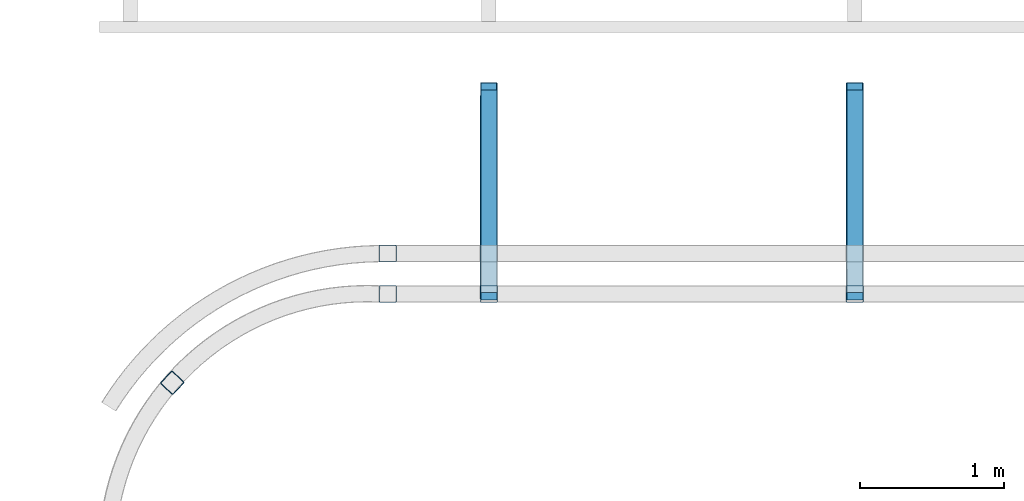
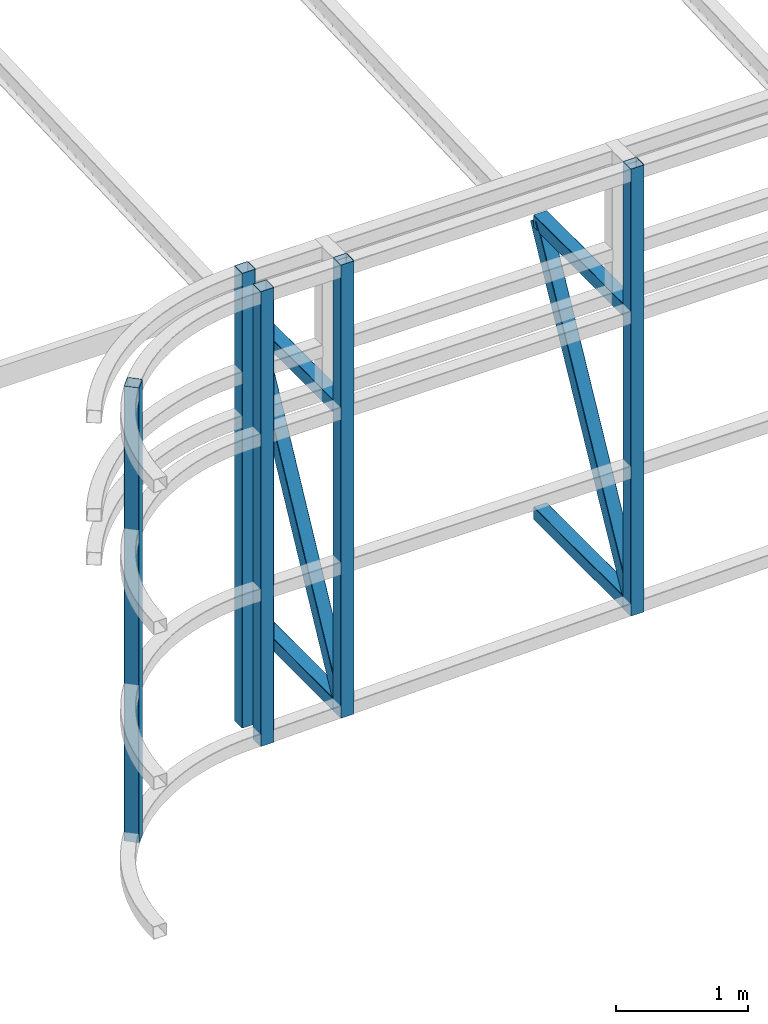
# One storey, part 105 of 215: 9 beams, 2 members, 11 elements without a shape of their own.
"""IFC2X3 building model written with IfcOpenShell, lengths in millimetres."""

from ifc_helpers import new_model, si_unit, frame, origin_with_axes, origin_2d_with_axis, place, context, subcontext, project, spatial, hollow_rectangle, extrude, material, type_object, element, aggregate, save


model = new_model("IFC2X3")

# Units and contexts
model_context = context("Model", 3, precision=1e-05, world=origin_with_axes())
body_context = subcontext(model_context, "Body", "Model", "MODEL_VIEW")
ifc_project = project(units=[si_unit("LENGTHUNIT", "METRE", prefix="MILLI"), si_unit("AREAUNIT", "SQUARE_METRE"), si_unit("VOLUMEUNIT", "CUBIC_METRE"), si_unit("MASSUNIT", "GRAM", prefix="KILO"), si_unit("TIMEUNIT", "SECOND"), si_unit("PLANEANGLEUNIT", "RADIAN"), si_unit("SOLIDANGLEUNIT", "STERADIAN"), si_unit("THERMODYNAMICTEMPERATUREUNIT", "DEGREE_CELSIUS"), si_unit("LUMINOUSINTENSITYUNIT", "LUMEN")], contexts=[model_context])

# Site, building, storey
site_placement = place(None, origin_with_axes())
site = spatial("IfcSite", under=ifc_project, at=site_placement, CompositionType="ELEMENT")
building_placement = place(site_placement, origin_with_axes())
building = spatial("IfcBuilding", under=site, at=building_placement, Name="Undefined", CompositionType="ELEMENT")
storey_placement = place(building_placement, origin_with_axes())
storey = spatial("IfcBuildingStorey", under=building, at=storey_placement, Name="Undefined", CompositionType="ELEMENT", Elevation=0.0)

# Assembly, beam
assembly_1_placement = place(storey_placement, origin_with_axes())
assembly_1 = element("IfcElementAssembly", 1, at=assembly_1_placement, inside=storey, Name="Steel Assembly", AssemblyPlace="NOTDEFINED", PredefinedType="RIGID_FRAME")
ifc_material = material(Name="STEEL/S275JR")
beam_type = type_object("IfcBeamType", PredefinedType="NOTDEFINED")
beam_1_placement = place(assembly_1_placement, frame((105963.049496376, 33419.9401986617, 4339.19100733164), z_axis=(-1.22999999439251e-06, -0.999999999999244, 0.0), x_axis=(0.0, 0.0, -1.0)))
beam_1 = element("IfcBeam", 2, at=beam_1_placement, type_object=beam_type, material=ifc_material, Name="LISSE", context=body_context, shape_type="SweptSolid", body=[
    extrude(hollow_rectangle(XDim=120.0, YDim=120.0, WallThickness=4.0, InnerFilletRadius=4.0, OuterFilletRadius=8.0, at=origin_2d_with_axis()), frame((4212.27305213816, 0.0, 0.0), z_axis=(-1.0, 0.0, 0.0), x_axis=(-6.93889390390723e-18, -1.0, -3.46944695195361e-18)), (0.0, 0.0, 1.0), 4212.3),
])
aggregate(assembly_1, [beam_1])

assembly_2_placement = place(storey_placement, origin_with_axes())
assembly_2 = element("IfcElementAssembly", 3, at=assembly_2_placement, inside=storey, Name="Steel Assembly", AssemblyPlace="NOTDEFINED", PredefinedType="RIGID_FRAME")
beam_2_placement = place(assembly_2_placement, frame((106665.007214263, 34554.8740277617, 201.30219434025), z_axis=(0.0, 0.0, 1.0), x_axis=(-6.93889390390723e-18, -1.0, -3.46944695195361e-18)))
beam_2 = element("IfcBeam", 4, at=beam_2_placement, type_object=beam_type, material=ifc_material, Name="LISSE", context=body_context, shape_type="SweptSolid", body=[
    extrude(hollow_rectangle(XDim=120.0, YDim=120.0, WallThickness=4.0, InnerFilletRadius=4.0, OuterFilletRadius=8.0, at=origin_2d_with_axis()), frame((1404.9181154153, 1.48751491493898e-19, -2.84217094304217e-14), z_axis=(-1.0, 0.0, 0.0), x_axis=(-6.93889390390723e-18, -1.0, -3.46944695195361e-18)), (0.0, 0.0, 1.0), 1404.9),
])
aggregate(assembly_2, [beam_2])

assembly_3_placement = place(storey_placement, origin_with_axes())
assembly_3 = element("IfcElementAssembly", 5, at=assembly_3_placement, inside=storey, Name="Steel Assembly", AssemblyPlace="NOTDEFINED", PredefinedType="RIGID_FRAME")
beam_3_placement = place(assembly_3_placement, frame((109205.009155207, 34554.8788879734, 258.197990203861), z_axis=(0.0, 0.0, 1.0), x_axis=(-6.93889390390723e-18, -1.0, -3.46944695195361e-18)))
beam_3 = element("IfcBeam", 6, at=beam_3_placement, type_object=beam_type, material=ifc_material, Name="LISSE", context=body_context, shape_type="SweptSolid", body=[
    extrude(hollow_rectangle(XDim=120.0, YDim=120.0, WallThickness=4.0, InnerFilletRadius=4.0, OuterFilletRadius=8.0, at=origin_2d_with_axis()), frame((1404.9181154153, 1.48751491493898e-19, -2.84217094304217e-14), z_axis=(-1.0, 0.0, 0.0), x_axis=(-6.93889390390723e-18, -1.0, -3.46944695195361e-18)), (0.0, 0.0, 1.0), 1404.9),
])
aggregate(assembly_3, [beam_3])

assembly_4_placement = place(storey_placement, origin_with_axes())
assembly_4 = element("IfcElementAssembly", 7, at=assembly_4_placement, inside=storey, Name="Steel Assembly", AssemblyPlace="NOTDEFINED", PredefinedType="RIGID_FRAME")
beam_4_placement = place(assembly_4_placement, frame((106665.008622264, 34554.8706212946, 2963.99602185051), z_axis=(0.0, 0.0, -1.0), x_axis=(-4.41999996209638e-07, -0.999999999999642, 7.22000000069896e-07)))
beam_4 = element("IfcBeam", 8, at=beam_4_placement, type_object=beam_type, material=ifc_material, Name="LISSE", context=body_context, shape_type="SweptSolid", body=[
    extrude(hollow_rectangle(XDim=120.0, YDim=120.0, WallThickness=4.0, InnerFilletRadius=4.0, OuterFilletRadius=8.0, at=origin_2d_with_axis()), frame((1404.89231313232, 5.39143026605448e-20, -1.48748759570922e-19), z_axis=(-1.0, 0.0, 0.0), x_axis=(-6.93889390390723e-18, -1.0, -3.46944695195361e-18)), (0.0, 0.0, 1.0), 1404.9),
])
aggregate(assembly_4, [beam_4])

assembly_5_placement = place(storey_placement, origin_with_axes())
assembly_5 = element("IfcElementAssembly", 9, at=assembly_5_placement, inside=storey, Name="Steel Assembly", AssemblyPlace="NOTDEFINED", PredefinedType="RIGID_FRAME")
beam_5_placement = place(assembly_5_placement, frame((109205.010563199, 34554.8754815795, 2963.99602185051), z_axis=(0.0, 0.0, -1.0), x_axis=(-4.41999996209638e-07, -0.999999999999642, 7.22000000069896e-07)))
beam_5 = element("IfcBeam", 10, at=beam_5_placement, type_object=beam_type, material=ifc_material, Name="LISSE", context=body_context, shape_type="SweptSolid", body=[
    extrude(hollow_rectangle(XDim=120.0, YDim=120.0, WallThickness=4.0, InnerFilletRadius=4.0, OuterFilletRadius=8.0, at=origin_2d_with_axis()), frame((1404.89231313232, 5.39143026605448e-20, -1.48748759570922e-19), z_axis=(-1.0, 0.0, 0.0), x_axis=(-6.93889390390723e-18, -1.0, -3.46944695195361e-18)), (0.0, 0.0, 1.0), 1404.9),
])
aggregate(assembly_5, [beam_5])

assembly_6_placement = place(storey_placement, origin_with_axes())
assembly_6 = element("IfcElementAssembly", 11, at=assembly_6_placement, inside=storey, Name="Steel Assembly", AssemblyPlace="NOTDEFINED", PredefinedType="RIGID_FRAME")
beam_6_placement = place(assembly_6_placement, frame((104467.161682127, 32523.1638216692, 4339.19096643382), z_axis=(0.730130673706851, -0.68330754372565, 0.0), x_axis=(0.0, 0.0, -1.0)))
beam_6 = element("IfcBeam", 12, at=beam_6_placement, type_object=beam_type, material=ifc_material, Name="LISSE", context=body_context, shape_type="SweptSolid", body=[
    extrude(hollow_rectangle(XDim=120.0, YDim=120.0, WallThickness=4.0, InnerFilletRadius=4.0, OuterFilletRadius=8.0, at=origin_2d_with_axis()), frame((4212.27305213816, 0.0, 0.0), z_axis=(-1.0, 0.0, 0.0), x_axis=(-6.93889390390723e-18, -1.0, -3.46944695195361e-18)), (0.0, 0.0, 1.0), 4212.3),
])
aggregate(assembly_6, [beam_6])

assembly_7_placement = place(storey_placement, origin_with_axes())
assembly_7 = element("IfcElementAssembly", 13, at=assembly_7_placement, inside=storey, Name="Steel Assembly", AssemblyPlace="NOTDEFINED", PredefinedType="RIGID_FRAME")
beam_7_placement = place(assembly_7_placement, frame((105963.050128326, 33139.9104810815, 4339.19097141913), z_axis=(-1.22999999439251e-06, -0.999999999999244, 0.0), x_axis=(0.0, 0.0, -1.0)))
beam_7 = element("IfcBeam", 14, at=beam_7_placement, type_object=beam_type, material=ifc_material, Name="LISSE", context=body_context, shape_type="SweptSolid", body=[
    extrude(hollow_rectangle(XDim=120.0, YDim=120.0, WallThickness=4.0, InnerFilletRadius=4.0, OuterFilletRadius=8.0, at=origin_2d_with_axis()), frame((4212.27305213816, 0.0, 0.0), z_axis=(-1.0, 0.0, 0.0), x_axis=(-6.93889390390723e-18, -1.0, -3.46944695195361e-18)), (0.0, 0.0, 1.0), 4212.3),
])
aggregate(assembly_7, [beam_7])

assembly_8_placement = place(storey_placement, origin_with_axes())
assembly_8 = element("IfcElementAssembly", 15, at=assembly_8_placement, inside=storey, Name="Steel Assembly", AssemblyPlace="NOTDEFINED", PredefinedType="RIGID_FRAME")
beam_8_placement = place(assembly_8_placement, frame((106665.008120459, 33139.9116030847, 4339.19097143199), z_axis=(1.91399999311775e-06, -0.999999999998168, 0.0), x_axis=(0.0, 0.0, -1.0)))
beam_8 = element("IfcBeam", 16, at=beam_8_placement, type_object=beam_type, material=ifc_material, Name="LISSE", context=body_context, shape_type="SweptSolid", body=[
    extrude(hollow_rectangle(XDim=120.0, YDim=120.0, WallThickness=4.0, InnerFilletRadius=4.0, OuterFilletRadius=8.0, at=origin_2d_with_axis()), frame((4196.55989394276, 0.0, 0.0), z_axis=(-1.0, 0.0, 0.0), x_axis=(-6.93889390390723e-18, -1.0, -3.46944695195361e-18)), (0.0, 0.0, 1.0), 4196.6),
])
aggregate(assembly_8, [beam_8])

assembly_9_placement = place(storey_placement, origin_with_axes())
assembly_9 = element("IfcElementAssembly", 17, at=assembly_9_placement, inside=storey, Name="Steel Assembly", AssemblyPlace="NOTDEFINED", PredefinedType="RIGID_FRAME")
beam_9_placement = place(assembly_9_placement, frame((109205.010058725, 33139.9164672962, 4339.19097146003), z_axis=(1.91399999311775e-06, -0.999999999998168, 0.0), x_axis=(0.0, 0.0, -1.0)))
beam_9 = element("IfcBeam", 18, at=beam_9_placement, type_object=beam_type, material=ifc_material, Name="LISSE", context=body_context, shape_type="SweptSolid", body=[
    extrude(hollow_rectangle(XDim=120.0, YDim=120.0, WallThickness=4.0, InnerFilletRadius=4.0, OuterFilletRadius=8.0, at=origin_2d_with_axis()), frame((4139.66414693749, 0.0, 0.0), z_axis=(-1.0, 0.0, 0.0), x_axis=(-6.93889390390723e-18, -1.0, -3.46944695195361e-18)), (0.0, 0.0, 1.0), 4139.7),
])
aggregate(assembly_9, [beam_9])

# Assembly, member
assembly_10_placement = place(storey_placement, origin_with_axes())
assembly_10 = element("IfcElementAssembly", 19, at=assembly_10_placement, inside=storey, Name="Steel Assembly", AssemblyPlace="NOTDEFINED", PredefinedType="RIGID_FRAME")
member_type = type_object("IfcMemberType", PredefinedType="NOTDEFINED")
member_1_placement = place(assembly_10_placement, frame((106665.006462518, 33149.9554479545, 261.302186840249), z_axis=(-0.000920454999945079, -0.887281587947549, 0.461227206972734), x_axis=(2.40399999856244e-06, 0.461227400015958, 0.8872819650307)))
member_1 = element("IfcMember", 20, at=member_1_placement, type_object=member_type, material=ifc_material, Name="LISSE", context=body_context, shape_type="SweptSolid", body=[
    extrude(hollow_rectangle(XDim=120.0, YDim=120.0, WallThickness=4.0, InnerFilletRadius=4.0, OuterFilletRadius=8.0, at=origin_2d_with_axis()), frame((3046.03715742064, 1.45517501023617e-11, 3.97615686569493e-12), z_axis=(-1.0, 0.0, 0.0), x_axis=(-6.93889390390723e-18, -1.0, -3.46944695195361e-18)), (0.0, 0.0, 1.0), 3046.0),
])
aggregate(assembly_10, [member_1])

assembly_11_placement = place(storey_placement, origin_with_axes())
assembly_11 = element("IfcElementAssembly", 21, at=assembly_11_placement, inside=storey, Name="Steel Assembly", AssemblyPlace="NOTDEFINED", PredefinedType="RIGID_FRAME")
member_2_placement = place(assembly_11_placement, frame((109205.008651172, 33149.9226043388, 319.570878641738), z_axis=(-0.00096943200021004, -0.883097841193109, 0.469187876102599), x_axis=(1.05440000000491e-05, 0.469188087076215, 0.883098261143451)))
member_2 = element("IfcMember", 22, at=member_2_placement, type_object=member_type, material=ifc_material, Name="LISSE", context=body_context, shape_type="SweptSolid", body=[
    extrude(hollow_rectangle(XDim=120.0, YDim=120.0, WallThickness=4.0, InnerFilletRadius=4.0, OuterFilletRadius=8.0, at=origin_2d_with_axis()), frame((2994.48573206715, 0.0, 3.80420615742434e-12), z_axis=(-1.0, 0.0, 0.0), x_axis=(-6.93889390390723e-18, -1.0, -3.46944695195361e-18)), (0.0, 0.0, 1.0), 2994.5),
])
aggregate(assembly_11, [member_2])

save(model, "model.ifc")
